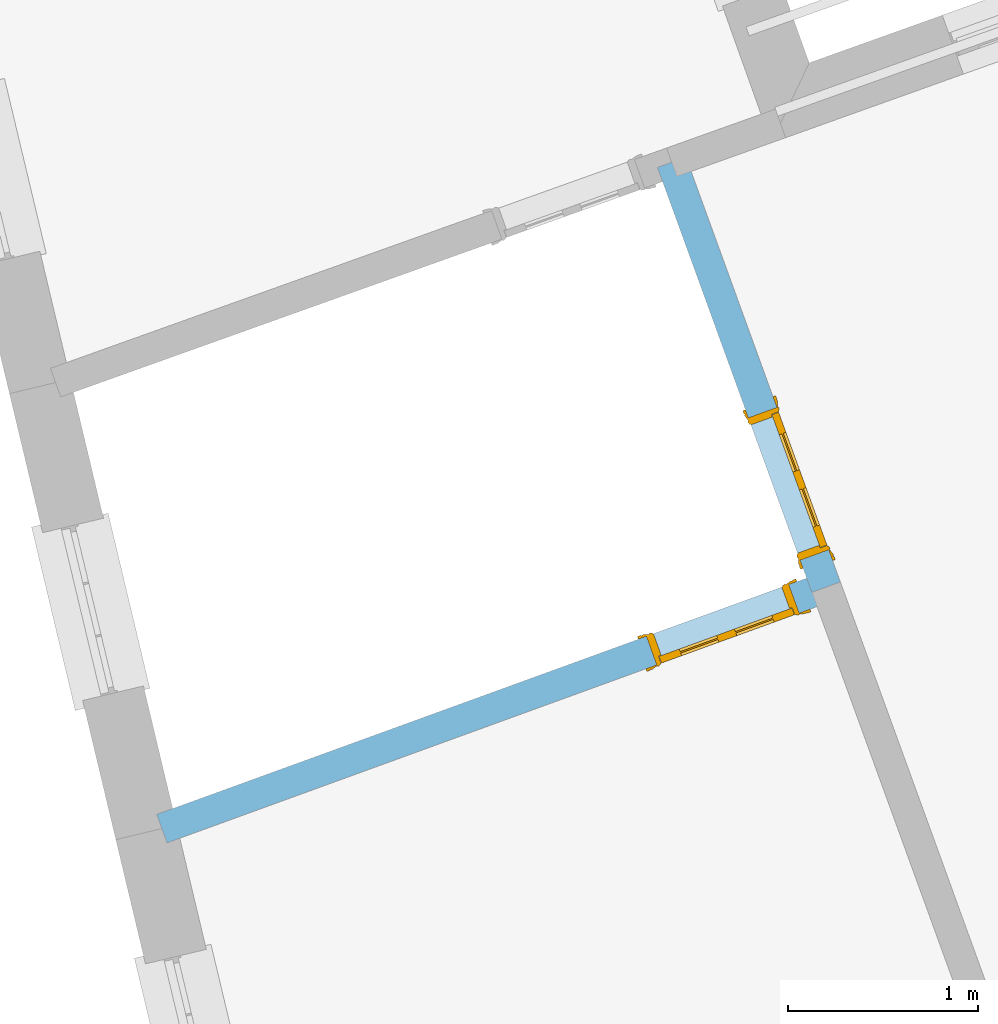
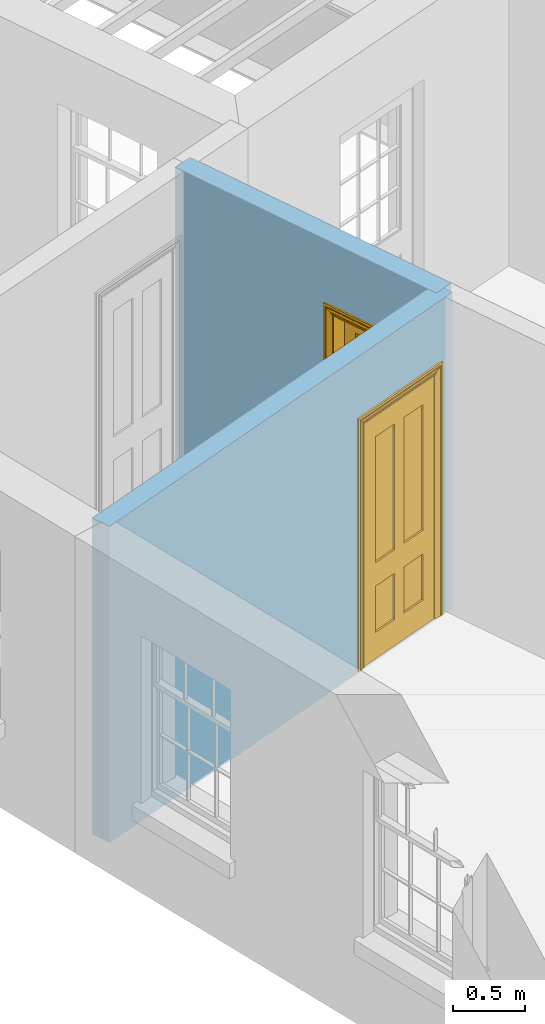
# One storey, part 6 of 12: 2 doors, 2 openings, plus 2 elements that do not belong to this part.
"""IFC2X3 building model written with IfcOpenShell, lengths in metres."""

from ifc_helpers import new_model, si_unit, frame, origin, place, context, subcontext, project, spatial, polyline, outline, extrude, faceted_brep, material, layer, layer_set, layer_usage, element, fill, save


model = new_model("IFC2X3")

# Units and contexts
model_context = context("Model", 3, world=origin())
body_context = subcontext(model_context, "Body", "Model", "MODEL_VIEW")
ifc_project = project(units=[si_unit("PLANEANGLEUNIT", "RADIAN"), si_unit("MASSUNIT", "GRAM", prefix="KILO"), si_unit("FORCEUNIT", "NEWTON", prefix="KILO"), si_unit("LENGTHUNIT", "METRE")], contexts=[model_context])

# Site, building, storey
site_placement = place(None, origin())
site = spatial("IfcSite", under=ifc_project, at=site_placement, CompositionType="ELEMENT")
building_placement = place(None, origin())
building = spatial("IfcBuilding", under=site, at=building_placement, Name="Building plot-12", CompositionType="ELEMENT")
storey_placement = place(None, frame((0.0, 0.0, 6.45)))
storey = spatial("IfcBuildingStorey", under=building, at=storey_placement, Name="Floor 1", CompositionType="ELEMENT", Elevation=6.45)

# Wall, opening, door
ifc_material = material(Name="Masonry")
ifc_layer = layer(ifc_material, 0.16, ventilated=False)
ifc_layer_set = layer_set([ifc_layer], Name="My Wall")
ifc_layer_usage = layer_usage(ifc_layer_set, "AXIS2", "NEGATIVE", 0.08)
wall_1_placement = place(storey_placement, origin())
wall_1 = element("IfcWallStandardCase", 1, at=wall_1_placement, inside=storey, material=ifc_layer_usage, Name="interior", context=body_context, shape_type="SweptSolid", body=[
    extrude(outline(polyline([(57.440249214637, 39.7494788479514), (57.2898785771558, 39.694810105662), (58.1046619048331, 37.4536850447771), (58.2550325423143, 37.5083537870665), (57.440249214637, 39.7494788479514)])), origin(), (0.0, 0.0, 1.0), 2.7),
])
opening_1_placement = place(storey_placement, frame((0.0, 0.0, 0.0199999999999996)))
opening_1 = element("IfcOpeningElement", 2, at=opening_1_placement, cuts=wall_1, Name="Opening", ObjectType="Opening", context=body_context, shape_type="SweptSolid", body=[
    extrude(outline(polyline([(57.7698158583105, 38.3747051993493), (58.0431595697575, 37.6228520119434), (58.1935302072387, 37.6775207542328), (57.9201864957916, 38.4293739416387), (57.7698158583105, 38.3747051993493)])), origin(), (0.0, 0.0, 1.0), 2.1),
])
door_1_placement = place(storey_placement, frame((57.845001177051, 38.402039570494, 0.0199999999999996), z_axis=(0.0, 0.0, 1.0), x_axis=(0.273343711447069, -0.75185318740585, 0.0)))
door_1 = element("IfcDoor", 3, at=door_1_placement, inside=storey, Name="bedroom inside door", OverallHeight=2.1, OverallWidth=0.8, context=body_context, shape_type="Brep", held_by="IfcProductRepresentation", body=[
    faceted_brep([(0.773, 0.08, 1.895), (0.66, 0.08, 1.895), (0.66, 0.08, 2.073), (0.773, 0.08, 2.073), (0.773, 0.08, 0.82), (0.66, 0.08, 0.82), (0.45, 0.08, 1.895), (0.45, 0.08, 2.073), (0.773, 0.08, 0.62), (0.66, 0.08, 0.62), (0.66, 0.065, 0.82), (0.66, 0.065, 1.895), (0.45, 0.065, 1.895), (0.35, 0.08, 1.895), (0.35, 0.08, 2.073), (0.773, 0.08, 0.225), (0.66, 0.08, 0.225), (0.45, 0.08, 0.62), (0.45, 0.08, 0.82), (0.45, 0.065, 0.82), (0.35, 0.08, 0.82), (0.14, 0.08, 2.073), (0.14, 0.08, 1.895), (0.773, 0.08, 0.0), (0.66, 0.08, 0.0), (0.66, 0.065, 0.225), (0.66, 0.065, 0.62), (0.45, 0.065, 0.62), (0.35, 0.08, 0.62), (0.35, 0.065, 0.82), (0.35, 0.065, 1.895), (0.14, 0.065, 1.895), (0.027, 0.08, 2.073), (0.027, 0.08, 1.895), (0.773, 0.042, 0.0), (0.66, 0.042, 0.0), (0.45, 0.08, 0.0), (0.45, 0.08, 0.225), (0.45, 0.065, 0.225), (0.35, 0.08, 0.225), (0.14, 0.08, 0.82), (0.14, 0.08, 0.62), (0.14, 0.065, 0.82), (0.027, 0.08, 0.82), (0.773, 0.042, 0.225), (0.66, 0.042, 0.225), (0.45, 0.042, 0.0), (0.35, 0.08, 0.0), (0.35, 0.065, 0.225), (0.35, 0.065, 0.62), (0.14, 0.065, 0.62), (0.027, 0.08, 0.62), (0.773, 0.042, 0.62), (0.66, 0.042, 0.62), (0.45, 0.042, 0.225), (0.35, 0.042, 0.0), (0.14, 0.08, 0.225), (0.14, 0.08, 0.0), (0.14, 0.065, 0.225), (0.027, 0.08, 0.225), (0.773, 0.042, 0.82), (0.66, 0.042, 0.82), (0.66, 0.057, 0.62), (0.66, 0.057, 0.225), (0.45, 0.057, 0.225), (0.35, 0.042, 0.225), (0.14, 0.042, 0.0), (0.027, 0.08, 0.0), (0.773, 0.042, 1.895), (0.66, 0.042, 1.895), (0.45, 0.042, 0.62), (0.45, 0.042, 0.82), (0.45, 0.057, 0.62), (0.35, 0.042, 0.62), (0.14, 0.042, 0.225), (0.027, 0.042, 0.0), (0.773, 0.042, 2.073), (0.66, 0.042, 2.073), (0.66, 0.057, 1.895), (0.66, 0.057, 0.82), (0.45, 0.057, 0.82), (0.35, 0.042, 0.82), (0.35, 0.057, 0.62), (0.35, 0.057, 0.225), (0.14, 0.057, 0.225), (0.027, 0.042, 0.225), (0.45, 0.042, 1.895), (0.45, 0.042, 2.073), (0.45, 0.057, 1.895), (0.35, 0.042, 1.895), (0.14, 0.042, 0.82), (0.14, 0.042, 0.62), (0.14, 0.057, 0.62), (0.027, 0.042, 0.62), (0.35, 0.042, 2.073), (0.35, 0.057, 1.895), (0.35, 0.057, 0.82), (0.14, 0.057, 0.82), (0.027, 0.042, 0.82), (0.14, 0.042, 2.073), (0.14, 0.042, 1.895), (0.14, 0.057, 1.895), (0.027, 0.042, 1.895), (0.027, 0.042, 2.073), (0.02, 0.085, 0.0), (0.005, 0.09, 0.0), (0.005, 0.09, 2.095), (0.02, 0.085, 2.08), (0.02, 0.08, 0.0), (0.0, 0.085, 0.0), (0.0, 0.085, 2.1), (0.795, 0.09, 2.095), (0.78, 0.085, 2.08), (0.02, 0.08, 2.08), (0.0, 0.08, 0.0), (-0.032, 0.095, 0.0), (-0.032, 0.095, 2.132), (0.8, 0.085, 2.1), (0.795, 0.09, 0.0), (0.78, 0.085, 0.0), (0.78, 0.08, 2.08), (0.04, 0.04, 0.0), (0.025, 0.04, 0.0), (0.025, 0.04, 2.075), (0.04, 0.04, 2.06), (-0.04, 0.09, 0.0), (-0.04, 0.09, 2.14), (0.832, 0.095, 2.132), (0.8, 0.085, 0.0), (0.78, 0.08, 0.0), (0.8, 0.08, 0.0), (0.86, 0.08, 0.0), (0.86, 0.08, 2.16), (0.8, 0.08, 2.1), (-0.06, 0.08, 2.16), (0.0, 0.08, 2.1), (-0.06, 0.08, 0.0), (-0.04, 0.095, 0.0), (-0.04, 0.095, 2.14), (0.84, 0.09, 2.14), (0.832, 0.095, 0.0), (0.84, 0.09, 0.0), (0.86, 0.095, 0.0), (0.86, 0.095, 2.16), (-0.06, 0.095, 2.16), (-0.06, 0.095, 0.0), (0.84, 0.095, 0.0), (0.84, 0.095, 2.14), (-0.025, -0.095, 0.0), (-0.025, -0.09, 0.0), (-0.025, -0.09, 2.125), (-0.025, -0.095, 2.125), (-0.017, -0.095, 0.0), (-0.017, -0.095, 2.117), (0.825, -0.09, 2.125), (0.825, -0.095, 2.125), (0.825, -0.095, 0.0), (0.845, -0.095, 0.0), (-0.045, -0.095, 2.145), (-0.045, -0.095, 0.0), (0.845, -0.095, 2.145), (0.015, -0.085, 0.0), (0.015, -0.085, 2.085), (0.817, -0.095, 2.117), (0.825, -0.09, 0.0), (0.845, -0.08, 0.0), (0.845, -0.08, 2.145), (-0.045, -0.08, 2.145), (-0.045, -0.08, 0.0), (0.02, -0.09, 0.0), (0.02, -0.09, 2.08), (0.785, -0.085, 2.085), (0.817, -0.095, 0.0), (0.8, -0.08, 0.0), (0.8, -0.08, 2.1), (0.0, -0.08, 2.1), (0.0, -0.08, 0.0), (0.035, -0.085, 0.0), (0.035, -0.085, 2.065), (0.78, -0.09, 2.08), (0.785, -0.085, 0.0), (0.775, 0.04, 2.075), (0.76, 0.04, 2.06), (0.035, -0.08, 2.065), (0.035, -0.08, 0.0), (0.765, -0.085, 2.065), (0.78, -0.09, 0.0), (0.765, -0.08, 0.0), (0.765, -0.08, 2.065), (0.765, -0.085, 0.0), (0.04, -0.08, 2.06), (0.04, -0.08, 0.0), (0.76, -0.08, 2.06), (0.76, -0.08, 0.0), (0.76, 0.04, 0.0), (0.775, 0.04, 0.0), (0.025, 0.08, 0.0), (0.025, 0.08, 2.075), (0.775, 0.08, 0.0), (0.775, 0.08, 2.075)], [[[0, 1, 2, 3]], [[1, 0, 4, 5]], [[1, 6, 7, 2]], [[8, 9, 5, 4]], [[1, 5, 10, 11]], [[6, 1, 11, 12]], [[6, 13, 14, 7]], [[15, 16, 9, 8]], [[9, 17, 18, 5]], [[5, 18, 19, 10]], [[10, 19, 12, 11]], [[18, 6, 12, 19]], [[18, 20, 13, 6]], [[21, 14, 13, 22]], [[23, 24, 16, 15]], [[9, 16, 25, 26]], [[17, 9, 26, 27]], [[17, 28, 20, 18]], [[13, 20, 29, 30]], [[22, 13, 30, 31]], [[32, 21, 22, 33]], [[34, 35, 24, 23]], [[24, 36, 37, 16]], [[16, 37, 38, 25]], [[25, 38, 27, 26]], [[37, 17, 27, 38]], [[37, 39, 28, 17]], [[40, 20, 28, 41]], [[20, 40, 42, 29]], [[31, 30, 29, 42]], [[40, 22, 31, 42]], [[33, 22, 40, 43]], [[35, 34, 44, 45]], [[35, 46, 36, 24]], [[36, 47, 39, 37]], [[28, 39, 48, 49]], [[41, 28, 49, 50]], [[43, 40, 41, 51]], [[45, 44, 52, 53]], [[46, 35, 45, 54]], [[46, 55, 47, 36]], [[56, 39, 47, 57]], [[39, 56, 58, 48]], [[50, 49, 48, 58]], [[56, 41, 50, 58]], [[51, 41, 56, 59]], [[53, 52, 60, 61]], [[45, 53, 62, 63]], [[54, 45, 63, 64]], [[55, 46, 54, 65]], [[55, 66, 57, 47]], [[59, 56, 57, 67]], [[61, 60, 68, 69]], [[70, 53, 61, 71]], [[53, 70, 72, 62]], [[72, 64, 63, 62]], [[70, 54, 64, 72]], [[65, 54, 70, 73]], [[65, 74, 66, 55]], [[67, 57, 66, 75]], [[69, 68, 76, 77]], [[61, 69, 78, 79]], [[71, 61, 79, 80]], [[73, 70, 71, 81]], [[65, 73, 82, 83]], [[74, 65, 83, 84]], [[74, 85, 75, 66]], [[86, 69, 77, 87]], [[69, 86, 88, 78]], [[88, 80, 79, 78]], [[86, 71, 80, 88]], [[81, 71, 86, 89]], [[73, 81, 90, 91]], [[73, 91, 92, 82]], [[83, 82, 92, 84]], [[91, 74, 84, 92]], [[91, 93, 85, 74]], [[89, 86, 87, 94]], [[81, 89, 95, 96]], [[90, 81, 96, 97]], [[90, 98, 93, 91]], [[94, 99, 100, 89]], [[89, 100, 101, 95]], [[101, 97, 96, 95]], [[100, 90, 97, 101]], [[100, 102, 98, 90]], [[99, 103, 102, 100]], [[32, 103, 99, 21]], [[102, 103, 32, 33]], [[98, 102, 33, 43]], [[21, 99, 94, 14]], [[94, 87, 7, 14]], [[7, 87, 77, 2]], [[76, 3, 2, 77]], [[43, 51, 93, 98]], [[51, 59, 85, 93]], [[67, 75, 85, 59]], [[34, 23, 15, 44]], [[44, 15, 8, 52]], [[52, 8, 4, 60]], [[0, 68, 60, 4]], [[0, 3, 76, 68]], [[104, 105, 106, 107]], [[104, 108, 109, 105]], [[105, 109, 110, 106]], [[107, 106, 111, 112]], [[107, 113, 108, 104]], [[114, 109, 108]], [[109, 115, 116, 110]], [[106, 110, 117, 111]], [[112, 111, 118, 119]], [[113, 107, 112, 120]], [[121, 122, 123, 124]], [[115, 109, 114, 125]], [[115, 125, 126, 116]], [[110, 116, 127, 117]], [[111, 117, 128, 118]], [[118, 128, 129, 119]], [[120, 112, 119, 129]], [[130, 129, 128]], [[130, 131, 132, 133]], [[133, 132, 134, 135]], [[135, 134, 136, 114]], [[136, 125, 114]], [[125, 137, 138, 126]], [[116, 126, 139, 127]], [[117, 127, 140, 128]], [[141, 130, 128, 140]], [[131, 130, 141]], [[131, 142, 143, 132]], [[132, 143, 144, 134]], [[134, 144, 145, 136]], [[137, 125, 136, 145]], [[143, 142, 146]], [[143, 146, 147]], [[137, 145, 144]], [[143, 147, 138]], [[138, 137, 144]], [[143, 138, 144]], [[126, 138, 147, 139]], [[127, 139, 141, 140]], [[142, 131, 141, 146]], [[139, 147, 146, 141]], [[148, 149, 150, 151]], [[149, 152, 153, 150]], [[151, 150, 154, 155]], [[155, 156, 157]], [[158, 159, 148]], [[158, 148, 151]], [[155, 157, 160]], [[158, 151, 155]], [[155, 160, 158]], [[152, 161, 162, 153]], [[150, 153, 163, 154]], [[155, 154, 164, 156]], [[156, 164, 165, 157]], [[157, 165, 166, 160]], [[160, 166, 167, 158]], [[158, 167, 168, 159]], [[161, 169, 170, 162]], [[153, 162, 171, 163]], [[154, 163, 172, 164]], [[165, 164, 173]], [[165, 173, 174, 166]], [[166, 174, 175, 167]], [[167, 175, 176, 168]], [[169, 177, 178, 170]], [[162, 170, 179, 171]], [[163, 171, 180, 172]], [[172, 180, 173, 164]], [[124, 123, 181, 182]], [[183, 178, 177, 184]], [[170, 178, 185, 179]], [[171, 179, 186, 180]], [[187, 173, 180]], [[185, 188, 187, 189]], [[188, 185, 178, 183]], [[179, 185, 189, 186]], [[189, 187, 180, 186]], [[190, 183, 184, 191]], [[192, 188, 183, 190]], [[191, 184, 122, 121]], [[124, 190, 191, 121]], [[193, 187, 188, 192]], [[182, 192, 190, 124]], [[184, 176, 122]], [[194, 195, 187, 193]], [[192, 182, 194, 193]], [[161, 176, 184]], [[114, 108, 122, 176]], [[173, 187, 195]], [[152, 149, 176, 161]], [[169, 161, 184, 177]], [[196, 122, 108]], [[176, 175, 135, 114]], [[173, 195, 129, 130]], [[176, 149, 168]], [[123, 122, 196, 197]], [[196, 108, 113, 197]], [[175, 174, 133, 135]], [[198, 129, 195]], [[133, 174, 173, 130]], [[159, 168, 149, 148]], [[181, 123, 197, 199]], [[197, 113, 120, 199]], [[199, 120, 129, 198]], [[195, 181, 199, 198]], [[195, 194, 182, 181]]]),
])
fill(opening_1, door_1)

wall_2_placement = place(storey_placement, origin())
wall_2 = element("IfcWallStandardCase", 4, at=wall_2_placement, inside=storey, material=ifc_layer_usage, Name="interior", context=body_context, shape_type="SweptSolid", body=[
    extrude(outline(polyline([(58.2071815947184, 37.4058340971812), (58.152512852429, 37.5562047346624), (54.6485074101103, 36.2822886715559), (54.7031761523997, 36.1319180340747), (58.2071815947184, 37.4058340971812)])), origin(), (0.0, 0.0, 1.0), 2.7),
])
opening_2_placement = place(storey_placement, frame((0.0, 0.0, 0.0199999999999996)))
opening_2 = element("IfcOpeningElement", 5, at=opening_2_placement, cuts=wall_2, Name="Opening", ObjectType="Opening", context=body_context, shape_type="SweptSolid", body=[
    extrude(outline(polyline([(57.9833458852627, 37.4947023995868), (57.2314926978568, 37.2213586881397), (57.2861614401462, 37.0709880506585), (58.0380146275521, 37.3443317621056), (57.9833458852627, 37.4947023995868)])), origin(), (0.0, 0.0, 1.0), 2.1),
])
door_2_placement = place(storey_placement, frame((58.0106802564074, 37.4195170808462, 0.0199999999999996), z_axis=(0.0, 0.0, 1.0), x_axis=(-0.75185318740585, -0.273343711447069, 0.0)))
door_2 = element("IfcDoor", 6, at=door_2_placement, inside=storey, Name="living inside door", OverallHeight=2.1, OverallWidth=0.8, context=body_context, shape_type="Brep", held_by="IfcProductRepresentation", body=[
    faceted_brep([(0.773, 0.08, 1.895), (0.66, 0.08, 1.895), (0.66, 0.08, 2.073), (0.773, 0.08, 2.073), (0.773, 0.08, 0.82), (0.66, 0.08, 0.82), (0.45, 0.08, 1.895), (0.45, 0.08, 2.073), (0.773, 0.08, 0.62), (0.66, 0.08, 0.62), (0.66, 0.065, 0.82), (0.66, 0.065, 1.895), (0.45, 0.065, 1.895), (0.35, 0.08, 1.895), (0.35, 0.08, 2.073), (0.773, 0.08, 0.225), (0.66, 0.08, 0.225), (0.45, 0.08, 0.62), (0.45, 0.08, 0.82), (0.45, 0.065, 0.82), (0.35, 0.08, 0.82), (0.14, 0.08, 2.073), (0.14, 0.08, 1.895), (0.773, 0.08, 0.0), (0.66, 0.08, 0.0), (0.66, 0.065, 0.225), (0.66, 0.065, 0.62), (0.45, 0.065, 0.62), (0.35, 0.08, 0.62), (0.35, 0.065, 0.82), (0.35, 0.065, 1.895), (0.14, 0.065, 1.895), (0.027, 0.08, 2.073), (0.027, 0.08, 1.895), (0.773, 0.042, 0.0), (0.66, 0.042, 0.0), (0.45, 0.08, 0.0), (0.45, 0.08, 0.225), (0.45, 0.065, 0.225), (0.35, 0.08, 0.225), (0.14, 0.08, 0.82), (0.14, 0.08, 0.62), (0.14, 0.065, 0.82), (0.027, 0.08, 0.82), (0.773, 0.042, 0.225), (0.66, 0.042, 0.225), (0.45, 0.042, 0.0), (0.35, 0.08, 0.0), (0.35, 0.065, 0.225), (0.35, 0.065, 0.62), (0.14, 0.065, 0.62), (0.027, 0.08, 0.62), (0.773, 0.042, 0.62), (0.66, 0.042, 0.62), (0.45, 0.042, 0.225), (0.35, 0.042, 0.0), (0.14, 0.08, 0.225), (0.14, 0.08, 0.0), (0.14, 0.065, 0.225), (0.027, 0.08, 0.225), (0.773, 0.042, 0.82), (0.66, 0.042, 0.82), (0.66, 0.057, 0.62), (0.66, 0.057, 0.225), (0.45, 0.057, 0.225), (0.35, 0.042, 0.225), (0.14, 0.042, 0.0), (0.027, 0.08, 0.0), (0.773, 0.042, 1.895), (0.66, 0.042, 1.895), (0.45, 0.042, 0.62), (0.45, 0.042, 0.82), (0.45, 0.057, 0.62), (0.35, 0.042, 0.62), (0.14, 0.042, 0.225), (0.027, 0.042, 0.0), (0.773, 0.042, 2.073), (0.66, 0.042, 2.073), (0.66, 0.057, 1.895), (0.66, 0.057, 0.82), (0.45, 0.057, 0.82), (0.35, 0.042, 0.82), (0.35, 0.057, 0.62), (0.35, 0.057, 0.225), (0.14, 0.057, 0.225), (0.027, 0.042, 0.225), (0.45, 0.042, 1.895), (0.45, 0.042, 2.073), (0.45, 0.057, 1.895), (0.35, 0.042, 1.895), (0.14, 0.042, 0.82), (0.14, 0.042, 0.62), (0.14, 0.057, 0.62), (0.027, 0.042, 0.62), (0.35, 0.042, 2.073), (0.35, 0.057, 1.895), (0.35, 0.057, 0.82), (0.14, 0.057, 0.82), (0.027, 0.042, 0.82), (0.14, 0.042, 2.073), (0.14, 0.042, 1.895), (0.14, 0.057, 1.895), (0.027, 0.042, 1.895), (0.027, 0.042, 2.073), (0.02, 0.085, 0.0), (0.005, 0.09, 0.0), (0.005, 0.09, 2.095), (0.02, 0.085, 2.08), (0.02, 0.08, 0.0), (0.0, 0.085, 0.0), (0.0, 0.085, 2.1), (0.795, 0.09, 2.095), (0.78, 0.085, 2.08), (0.02, 0.08, 2.08), (0.0, 0.08, 0.0), (-0.032, 0.095, 0.0), (-0.032, 0.095, 2.132), (0.8, 0.085, 2.1), (0.795, 0.09, 0.0), (0.78, 0.085, 0.0), (0.78, 0.08, 2.08), (0.04, 0.04, 0.0), (0.025, 0.04, 0.0), (0.025, 0.04, 2.075), (0.04, 0.04, 2.06), (-0.04, 0.09, 0.0), (-0.04, 0.09, 2.14), (0.832, 0.095, 2.132), (0.8, 0.085, 0.0), (0.78, 0.08, 0.0), (0.8, 0.08, 0.0), (0.86, 0.08, 0.0), (0.86, 0.08, 2.16), (0.8, 0.08, 2.1), (-0.06, 0.08, 2.16), (0.0, 0.08, 2.1), (-0.06, 0.08, 0.0), (-0.04, 0.095, 0.0), (-0.04, 0.095, 2.14), (0.84, 0.09, 2.14), (0.832, 0.095, 0.0), (0.84, 0.09, 0.0), (0.86, 0.095, 0.0), (0.86, 0.095, 2.16), (-0.06, 0.095, 2.16), (-0.06, 0.095, 0.0), (0.84, 0.095, 0.0), (0.84, 0.095, 2.14), (-0.025, -0.095, 0.0), (-0.025, -0.09, 0.0), (-0.025, -0.09, 2.125), (-0.025, -0.095, 2.125), (-0.017, -0.095, 0.0), (-0.017, -0.095, 2.117), (0.825, -0.09, 2.125), (0.825, -0.095, 2.125), (0.825, -0.095, 0.0), (0.845, -0.095, 0.0), (-0.045, -0.095, 2.145), (-0.045, -0.095, 0.0), (0.845, -0.095, 2.145), (0.015, -0.085, 0.0), (0.015, -0.085, 2.085), (0.817, -0.095, 2.117), (0.825, -0.09, 0.0), (0.845, -0.08, 0.0), (0.845, -0.08, 2.145), (-0.045, -0.08, 2.145), (-0.045, -0.08, 0.0), (0.02, -0.09, 0.0), (0.02, -0.09, 2.08), (0.785, -0.085, 2.085), (0.817, -0.095, 0.0), (0.8, -0.08, 0.0), (0.8, -0.08, 2.1), (0.0, -0.08, 2.1), (0.0, -0.08, 0.0), (0.035, -0.085, 0.0), (0.035, -0.085, 2.065), (0.78, -0.09, 2.08), (0.785, -0.085, 0.0), (0.775, 0.04, 2.075), (0.76, 0.04, 2.06), (0.035, -0.08, 2.065), (0.035, -0.08, 0.0), (0.765, -0.085, 2.065), (0.78, -0.09, 0.0), (0.765, -0.08, 0.0), (0.765, -0.08, 2.065), (0.765, -0.085, 0.0), (0.04, -0.08, 2.06), (0.04, -0.08, 0.0), (0.76, -0.08, 2.06), (0.76, -0.08, 0.0), (0.76, 0.04, 0.0), (0.775, 0.04, 0.0), (0.025, 0.08, 0.0), (0.025, 0.08, 2.075), (0.775, 0.08, 0.0), (0.775, 0.08, 2.075)], [[[0, 1, 2, 3]], [[1, 0, 4, 5]], [[1, 6, 7, 2]], [[8, 9, 5, 4]], [[1, 5, 10, 11]], [[6, 1, 11, 12]], [[6, 13, 14, 7]], [[15, 16, 9, 8]], [[9, 17, 18, 5]], [[5, 18, 19, 10]], [[10, 19, 12, 11]], [[18, 6, 12, 19]], [[18, 20, 13, 6]], [[21, 14, 13, 22]], [[23, 24, 16, 15]], [[9, 16, 25, 26]], [[17, 9, 26, 27]], [[17, 28, 20, 18]], [[13, 20, 29, 30]], [[22, 13, 30, 31]], [[32, 21, 22, 33]], [[34, 35, 24, 23]], [[24, 36, 37, 16]], [[16, 37, 38, 25]], [[25, 38, 27, 26]], [[37, 17, 27, 38]], [[37, 39, 28, 17]], [[40, 20, 28, 41]], [[20, 40, 42, 29]], [[31, 30, 29, 42]], [[40, 22, 31, 42]], [[33, 22, 40, 43]], [[35, 34, 44, 45]], [[35, 46, 36, 24]], [[36, 47, 39, 37]], [[28, 39, 48, 49]], [[41, 28, 49, 50]], [[43, 40, 41, 51]], [[45, 44, 52, 53]], [[46, 35, 45, 54]], [[46, 55, 47, 36]], [[56, 39, 47, 57]], [[39, 56, 58, 48]], [[50, 49, 48, 58]], [[56, 41, 50, 58]], [[51, 41, 56, 59]], [[53, 52, 60, 61]], [[45, 53, 62, 63]], [[54, 45, 63, 64]], [[55, 46, 54, 65]], [[55, 66, 57, 47]], [[59, 56, 57, 67]], [[61, 60, 68, 69]], [[70, 53, 61, 71]], [[53, 70, 72, 62]], [[72, 64, 63, 62]], [[70, 54, 64, 72]], [[65, 54, 70, 73]], [[65, 74, 66, 55]], [[67, 57, 66, 75]], [[69, 68, 76, 77]], [[61, 69, 78, 79]], [[71, 61, 79, 80]], [[73, 70, 71, 81]], [[65, 73, 82, 83]], [[74, 65, 83, 84]], [[74, 85, 75, 66]], [[86, 69, 77, 87]], [[69, 86, 88, 78]], [[88, 80, 79, 78]], [[86, 71, 80, 88]], [[81, 71, 86, 89]], [[73, 81, 90, 91]], [[73, 91, 92, 82]], [[83, 82, 92, 84]], [[91, 74, 84, 92]], [[91, 93, 85, 74]], [[89, 86, 87, 94]], [[81, 89, 95, 96]], [[90, 81, 96, 97]], [[90, 98, 93, 91]], [[94, 99, 100, 89]], [[89, 100, 101, 95]], [[101, 97, 96, 95]], [[100, 90, 97, 101]], [[100, 102, 98, 90]], [[99, 103, 102, 100]], [[32, 103, 99, 21]], [[102, 103, 32, 33]], [[98, 102, 33, 43]], [[21, 99, 94, 14]], [[94, 87, 7, 14]], [[7, 87, 77, 2]], [[76, 3, 2, 77]], [[43, 51, 93, 98]], [[51, 59, 85, 93]], [[67, 75, 85, 59]], [[34, 23, 15, 44]], [[44, 15, 8, 52]], [[52, 8, 4, 60]], [[0, 68, 60, 4]], [[0, 3, 76, 68]], [[104, 105, 106, 107]], [[104, 108, 109, 105]], [[105, 109, 110, 106]], [[107, 106, 111, 112]], [[107, 113, 108, 104]], [[114, 109, 108]], [[109, 115, 116, 110]], [[106, 110, 117, 111]], [[112, 111, 118, 119]], [[113, 107, 112, 120]], [[121, 122, 123, 124]], [[115, 109, 114, 125]], [[115, 125, 126, 116]], [[110, 116, 127, 117]], [[111, 117, 128, 118]], [[118, 128, 129, 119]], [[120, 112, 119, 129]], [[130, 129, 128]], [[130, 131, 132, 133]], [[133, 132, 134, 135]], [[135, 134, 136, 114]], [[136, 125, 114]], [[125, 137, 138, 126]], [[116, 126, 139, 127]], [[117, 127, 140, 128]], [[141, 130, 128, 140]], [[131, 130, 141]], [[131, 142, 143, 132]], [[132, 143, 144, 134]], [[134, 144, 145, 136]], [[137, 125, 136, 145]], [[143, 142, 146]], [[143, 146, 147]], [[137, 145, 144]], [[143, 147, 138]], [[138, 137, 144]], [[143, 138, 144]], [[126, 138, 147, 139]], [[127, 139, 141, 140]], [[142, 131, 141, 146]], [[139, 147, 146, 141]], [[148, 149, 150, 151]], [[149, 152, 153, 150]], [[151, 150, 154, 155]], [[155, 156, 157]], [[158, 159, 148]], [[158, 148, 151]], [[155, 157, 160]], [[158, 151, 155]], [[155, 160, 158]], [[152, 161, 162, 153]], [[150, 153, 163, 154]], [[155, 154, 164, 156]], [[156, 164, 165, 157]], [[157, 165, 166, 160]], [[160, 166, 167, 158]], [[158, 167, 168, 159]], [[161, 169, 170, 162]], [[153, 162, 171, 163]], [[154, 163, 172, 164]], [[165, 164, 173]], [[165, 173, 174, 166]], [[166, 174, 175, 167]], [[167, 175, 176, 168]], [[169, 177, 178, 170]], [[162, 170, 179, 171]], [[163, 171, 180, 172]], [[172, 180, 173, 164]], [[124, 123, 181, 182]], [[183, 178, 177, 184]], [[170, 178, 185, 179]], [[171, 179, 186, 180]], [[187, 173, 180]], [[185, 188, 187, 189]], [[188, 185, 178, 183]], [[179, 185, 189, 186]], [[189, 187, 180, 186]], [[190, 183, 184, 191]], [[192, 188, 183, 190]], [[191, 184, 122, 121]], [[124, 190, 191, 121]], [[193, 187, 188, 192]], [[182, 192, 190, 124]], [[184, 176, 122]], [[194, 195, 187, 193]], [[192, 182, 194, 193]], [[161, 176, 184]], [[114, 108, 122, 176]], [[173, 187, 195]], [[152, 149, 176, 161]], [[169, 161, 184, 177]], [[196, 122, 108]], [[176, 175, 135, 114]], [[173, 195, 129, 130]], [[176, 149, 168]], [[123, 122, 196, 197]], [[196, 108, 113, 197]], [[175, 174, 133, 135]], [[198, 129, 195]], [[133, 174, 173, 130]], [[159, 168, 149, 148]], [[181, 123, 197, 199]], [[197, 113, 120, 199]], [[199, 120, 129, 198]], [[195, 181, 199, 198]], [[195, 194, 182, 181]]]),
])
fill(opening_2, door_2)

save(model, "model.ifc")
